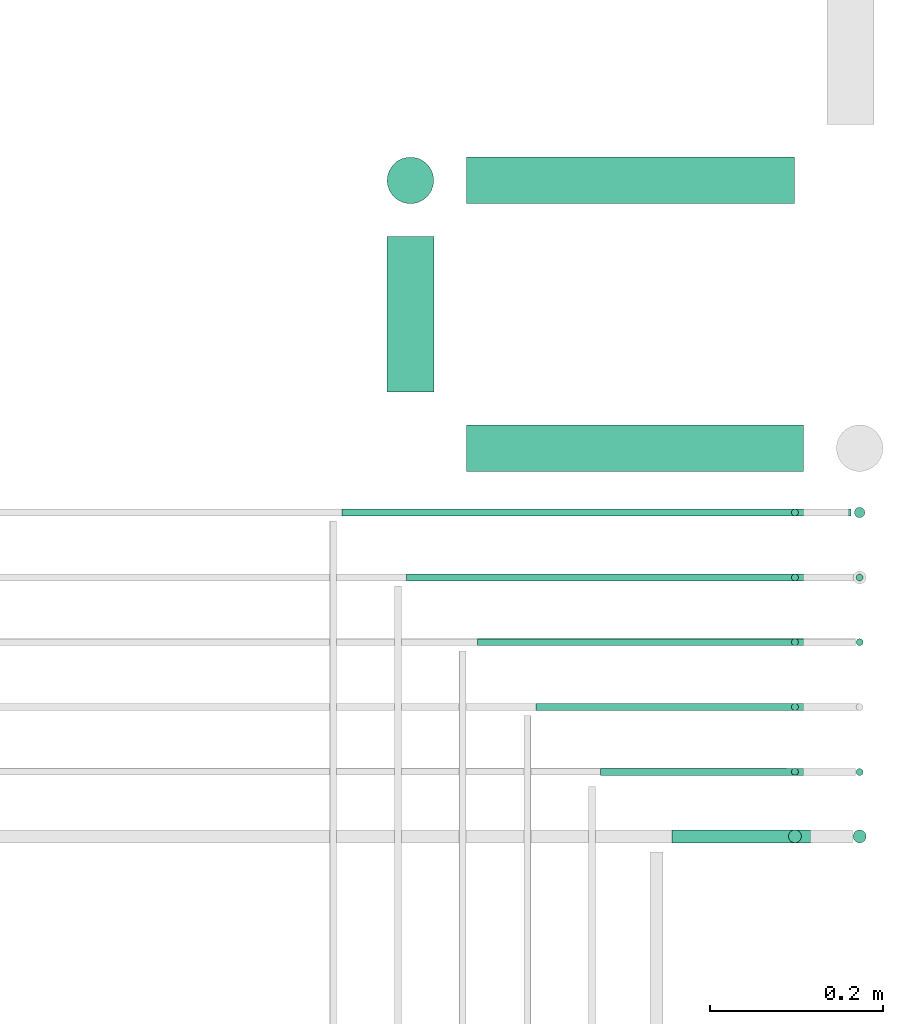
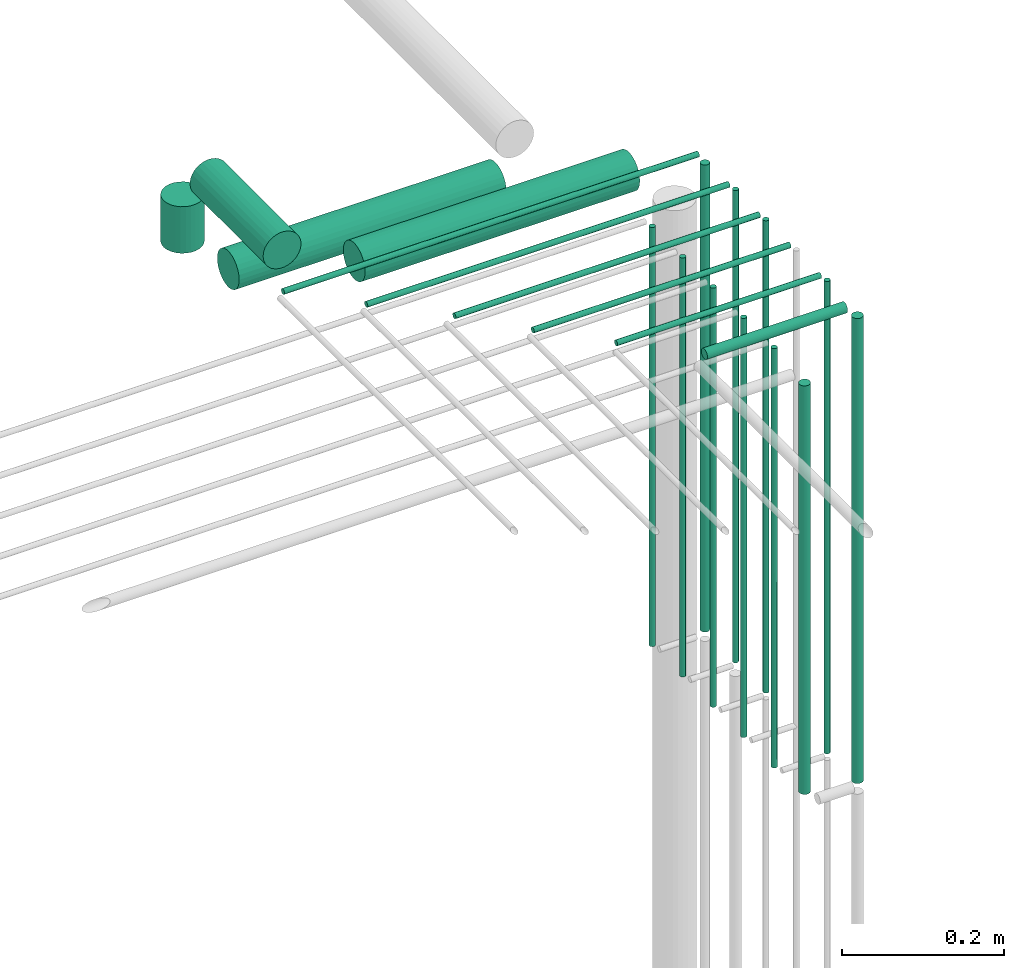
# One storey, part 60 of 89: 21 flow segments.
"""IFC2X3 building model written with IfcOpenShell, lengths in millimetres."""

import ifcopenshell
import ifcopenshell.guid

model = None  # the IFC model being written
_history = None  # IfcOwnerHistory: only IFC2X3 demands one
_inside = {}  # id of a spatial element -> (the spatial element, [elements in it])
_under = {}  # id of a project, library or spatial element -> (it, [spatial elements below it])
_declared = {}  # id of a project -> (the project, [libraries it declares])
_typed = {}  # id of a type object -> (the type object, [elements of that type])
_made_of = {}  # id of a material, layer set ... -> (it, [elements and type objects made of it])


def new_model(schema):
    """Start an empty IFC model of exactly this schema.

    Asked for "IFC4X3", IfcOpenShell would pick the latest addendum, in which some entities
    have other attributes; the version numbers below select the first issue.
    IFC2X3 requires an IfcOwnerHistory on every rooted entity: one is made here for all.
    """
    global model, _history
    if schema == "IFC4X3":
        model = ifcopenshell.file(schema_version=(4, 3, 0, 0))
    else:
        model = ifcopenshell.file(schema=schema)
    _inside.clear()
    _under.clear()
    _declared.clear()
    _typed.clear()
    _made_of.clear()
    _history = None
    if model.schema == "IFC2X3":
        org = make("IfcOrganization", Name="unknown")
        user = make(
            "IfcPersonAndOrganization",
            ThePerson=make("IfcPerson", FamilyName="unknown"),
            TheOrganization=org,
        )
        app = make(
            "IfcApplication",
            ApplicationDeveloper=org,
            Version="unknown",
            ApplicationFullName="unknown",
            ApplicationIdentifier="unknown",
        )
        _history = make(
            "IfcOwnerHistory",
            OwningUser=user,
            OwningApplication=app,
            ChangeAction="ADDED",
            CreationDate=0,
        )
    return model


def make(cls, **values):
    """One entity of the class cls with the attributes given. An attribute that is None is left unset."""
    return model.create_entity(
        cls, **{name: value for name, value in values.items() if value is not None}
    )


def entity(cls, *values):
    """Any entity or typed value of the class cls, its attributes in the order of the schema. None: left unset."""
    e = model.create_entity(cls)
    for i, value in enumerate(values):
        if value is not None:
            e[i] = value
    return e


def rooted(cls, **values):
    """An entity with a GlobalId (a new one), such as an element, a storey or a relation."""
    return make(cls, GlobalId=ifcopenshell.guid.new(), OwnerHistory=_history, **values)


def si_unit(unit_type, name, prefix=None):
    """IfcSIUnit, for example si_unit("LENGTHUNIT", "METRE", prefix="MILLI")."""
    return make("IfcSIUnit", UnitType=unit_type, Prefix=prefix, Name=name)


def converted_unit(unit_type, name, factor, base, dimensions=None, offset=None):
    """IfcConversionBasedUnit, such as the inch: factor (a typed value) times the base unit."""
    return make(
        "IfcConversionBasedUnit"
        if offset is None
        else "IfcConversionBasedUnitWithOffset",
        ConversionOffset=offset,
        Dimensions=None
        if dimensions is None
        else entity("IfcDimensionalExponents", *dimensions),
        UnitType=unit_type,
        Name=name,
        ConversionFactor=make(
            "IfcMeasureWithUnit", ValueComponent=factor, UnitComponent=base
        ),
    )


def derived_unit(unit_type, elements):
    """IfcDerivedUnit: a product of units, each with its exponent."""
    return make(
        "IfcDerivedUnit",
        Elements=[
            make("IfcDerivedUnitElement", Unit=unit, Exponent=power)
            for unit, power in elements
        ],
        UnitType=unit_type,
    )


def assignment(units):
    """IfcUnitAssignment: the units of a project."""
    return None if units is None else make("IfcUnitAssignment", Units=units)


def point(xyz):
    """IfcCartesianPoint."""
    return None if xyz is None else make("IfcCartesianPoint", Coordinates=xyz)


def direction(xyz):
    """IfcDirection."""
    return None if xyz is None else make("IfcDirection", DirectionRatios=xyz)


def frame(location, z_axis=None, x_axis=None):
    """IfcAxis2Placement3D, a coordinate frame: its origin and axes. An axis left out is left unset."""
    return make(
        "IfcAxis2Placement3D",
        Location=point(location),
        Axis=direction(z_axis),
        RefDirection=direction(x_axis),
    )


def frame_2d(location, x_axis=None):
    """IfcAxis2Placement2D, a coordinate frame in the plane: its origin and x axis."""
    return make(
        "IfcAxis2Placement2D", Location=point(location), RefDirection=direction(x_axis)
    )


def origin():
    """The frame at (0, 0, 0) with its axes left unset."""
    return frame((0.0, 0.0, 0.0))


def origin_2d_with_axis():
    """The frame at (0, 0) in the plane with the x axis (1, 0) written out."""
    return frame_2d((0.0, 0.0), x_axis=(1.0, 0.0))


def place(relative_to, where):
    """IfcLocalPlacement: puts the frame where relative to a parent placement (None: the world)."""
    return make(
        "IfcLocalPlacement", PlacementRelTo=relative_to, RelativePlacement=where
    )


def context(
    kind, dimensions, precision=None, world=None, true_north=None, identifier=None
):
    """IfcGeometricRepresentationContext, for example the 3D "Model" context."""
    return make(
        "IfcGeometricRepresentationContext",
        ContextIdentifier=identifier,
        ContextType=kind,
        CoordinateSpaceDimension=dimensions,
        Precision=precision,
        WorldCoordinateSystem=world,
        TrueNorth=true_north,
    )


def subcontext(parent, identifier, kind, view, scale=None):
    """IfcGeometricRepresentationSubContext, for example "Body" below "Model"."""
    return make(
        "IfcGeometricRepresentationSubContext",
        ContextIdentifier=identifier,
        ContextType=kind,
        ParentContext=parent,
        TargetScale=scale,
        TargetView=view,
    )


def project(units=None, contexts=None):
    """IfcProject with its units and contexts."""
    return rooted(
        "IfcProject",
        Name="project",
        RepresentationContexts=contexts,
        UnitsInContext=assignment(units),
    )


def spatial(cls, under=None, at=None, **own):
    """A site, building, storey or space (cls), placed at a placement, below another one or the project."""
    s = rooted(cls, ObjectPlacement=at, **own)
    if under is not None:
        _under.setdefault(under.id(), (under, []))[1].append(s)
    return s


def polyline(points):
    """IfcPolyline through the points."""
    return make("IfcPolyline", Points=[point(p) for p in points])


def profile(cls, at=None, kind="AREA", **sizes):
    """A parametric profile (cls). Its sizes go by their IFC names, for example OverallWidth=200.0."""
    return make(cls, ProfileType=kind, Position=at, **sizes)


def circle(**sizes):
    """IfcCircleProfileDef."""
    return profile("IfcCircleProfileDef", **sizes)


def outline(outer, holes=None, kind="AREA"):
    """IfcArbitraryClosedProfileDef: a profile drawn as a closed curve; with holes, ...WithVoids."""
    if holes is None:
        return make("IfcArbitraryClosedProfileDef", ProfileType=kind, OuterCurve=outer)
    return make(
        "IfcArbitraryProfileDefWithVoids",
        ProfileType=kind,
        OuterCurve=outer,
        InnerCurves=holes,
    )


def extrude(swept, where, along, depth):
    """IfcExtrudedAreaSolid: the profile swept, set in the frame where, extruded along a direction by depth."""
    return make(
        "IfcExtrudedAreaSolid",
        SweptArea=swept,
        Position=where,
        ExtrudedDirection=direction(along),
        Depth=depth,
    )


def shape(context_of_items, identifier, shape_type, items):
    """IfcShapeRepresentation: the items that make up one representation, for example the "Body"."""
    return make(
        "IfcShapeRepresentation",
        ContextOfItems=context_of_items,
        RepresentationIdentifier=identifier,
        RepresentationType=shape_type,
        Items=items,
    )


def made_of(thing, what):
    """Note that an element or type object is made of a material, layer set ...; save() writes the relation."""
    if what is not None:
        _made_of.setdefault(what.id(), (what, []))[1].append(thing)
    return thing


def type_object(cls, material=None, **own):
    """A type object (cls), such as IfcWallType, which elements share."""
    return made_of(rooted(cls, **own), material)


def element(
    cls,
    number,
    at=None,
    inside=None,
    cuts=None,
    type_object=None,
    material=None,
    context=None,
    identifier="Body",
    shape_type=None,
    held_by="IfcProductDefinitionShape",
    body=None,
    shapes=None,
    **own,
):
    """One element of the class cls, such as IfcWall. Its Tag is "e" and its number.

    at: its placement. inside: the storey or other place that contains it. cuts: it is an
    opening in that element (IfcRelVoidsElement). A single representation is given by context,
    identifier, shape_type and body (its items); several are given by shapes. held_by: the class
    of the entity that holds the representations. save() writes the other relations.
    """
    e = rooted(cls, Tag="e%d" % number, ObjectPlacement=at, **own)
    if body is not None:
        shapes = [shape(context, identifier, shape_type, body)]
    if shapes is not None:
        e.Representation = make(held_by, Representations=shapes)
    if inside is not None:
        _inside.setdefault(inside.id(), (inside, []))[1].append(e)
    if cuts is not None:
        rooted(
            "IfcRelVoidsElement", RelatingBuildingElement=cuts, RelatedOpeningElement=e
        )
    if type_object is not None:
        _typed.setdefault(type_object.id(), (type_object, []))[1].append(e)
    return made_of(e, material)


def aggregate(whole, parts):
    """IfcRelAggregates: a whole, such as a stair, and the parts it consists of."""
    return rooted("IfcRelAggregates", RelatingObject=whole, RelatedObjects=parts)


def save(model, path):
    """Write the relations noted so far, then the file.

    IfcRelAggregates (storeys below a building ...), IfcRelContainedInSpatialStructure (elements
    in a storey), IfcRelDefinesByType, IfcRelAssociatesMaterial and IfcRelDeclares: one each for
    every whole, place, type object, material and project.
    """
    for whole, parts in _under.values():
        aggregate(whole, parts)
    for where, things in _inside.values():
        rooted(
            "IfcRelContainedInSpatialStructure",
            RelatedElements=things,
            RelatingStructure=where,
        )
    for kind, things in _typed.values():
        rooted("IfcRelDefinesByType", RelatedObjects=things, RelatingType=kind)
    for what, things in _made_of.values():
        rooted("IfcRelAssociatesMaterial", RelatedObjects=things, RelatingMaterial=what)
    for by, libraries in _declared.values():
        rooted("IfcRelDeclares", RelatingContext=by, RelatedDefinitions=libraries)
    model.write(path)


model = new_model("IFC2X3")

# Units and contexts
model_context = context("Model", 3, precision=0.01, world=origin(), true_north=direction((6.12303176911189e-17, 1.0)))
body_context = subcontext(model_context, "Body", "Model", "MODEL_VIEW")
ifc_project = project(units=[si_unit("LENGTHUNIT", "METRE", prefix="MILLI"), si_unit("AREAUNIT", "SQUARE_METRE"), si_unit("VOLUMEUNIT", "CUBIC_METRE"), converted_unit("PLANEANGLEUNIT", "DEGREE", entity("IfcRatioMeasure", 0.0174532925199433), si_unit("PLANEANGLEUNIT", "RADIAN"), dimensions=[0, 0, 0, 0, 0, 0, 0]), si_unit("MASSUNIT", "GRAM", prefix="KILO"), derived_unit("MASSDENSITYUNIT", [(si_unit("MASSUNIT", "GRAM", prefix="KILO"), 1), (si_unit("LENGTHUNIT", "METRE"), -3)]), derived_unit("MOMENTOFINERTIAUNIT", [(si_unit("LENGTHUNIT", "METRE"), 4)]), si_unit("TIMEUNIT", "SECOND"), si_unit("FREQUENCYUNIT", "HERTZ"), si_unit("THERMODYNAMICTEMPERATUREUNIT", "DEGREE_CELSIUS"), derived_unit("THERMALTRANSMITTANCEUNIT", [(si_unit("MASSUNIT", "GRAM", prefix="KILO"), 1), (si_unit("THERMODYNAMICTEMPERATUREUNIT", "KELVIN"), -1), (si_unit("TIMEUNIT", "SECOND"), -3)]), derived_unit("VOLUMETRICFLOWRATEUNIT", [(si_unit("LENGTHUNIT", "METRE"), 3), (si_unit("TIMEUNIT", "SECOND"), -1)]), derived_unit("MASSFLOWRATEUNIT", [(si_unit("MASSUNIT", "GRAM", prefix="KILO"), 1), (si_unit("TIMEUNIT", "SECOND"), -1)]), derived_unit("ROTATIONALFREQUENCYUNIT", [(si_unit("TIMEUNIT", "SECOND"), -1)]), si_unit("ELECTRICCURRENTUNIT", "AMPERE"), si_unit("ELECTRICVOLTAGEUNIT", "VOLT"), si_unit("POWERUNIT", "WATT"), si_unit("FORCEUNIT", "NEWTON", prefix="KILO"), si_unit("ILLUMINANCEUNIT", "LUX"), si_unit("LUMINOUSFLUXUNIT", "LUMEN"), si_unit("LUMINOUSINTENSITYUNIT", "CANDELA"), derived_unit("USERDEFINED", [(si_unit("MASSUNIT", "GRAM", prefix="KILO"), -1), (si_unit("LENGTHUNIT", "METRE"), -2), (si_unit("TIMEUNIT", "SECOND"), 3), (si_unit("LUMINOUSFLUXUNIT", "LUMEN"), 1)]), derived_unit("LINEARVELOCITYUNIT", [(si_unit("LENGTHUNIT", "METRE"), 1), (si_unit("TIMEUNIT", "SECOND"), -1)]), si_unit("PRESSUREUNIT", "PASCAL"), derived_unit("USERDEFINED", [(si_unit("LENGTHUNIT", "METRE"), -2), (si_unit("MASSUNIT", "GRAM", prefix="KILO"), 1), (si_unit("TIMEUNIT", "SECOND"), -2)]), derived_unit("LINEARFORCEUNIT", [(si_unit("MASSUNIT", "GRAM", prefix="KILO"), 1), (si_unit("LENGTHUNIT", "METRE"), 1), (si_unit("TIMEUNIT", "SECOND"), -2), (si_unit("LENGTHUNIT", "METRE"), -1)]), derived_unit("PLANARFORCEUNIT", [(si_unit("MASSUNIT", "GRAM", prefix="KILO"), 1), (si_unit("LENGTHUNIT", "METRE"), 1), (si_unit("TIMEUNIT", "SECOND"), -2), (si_unit("LENGTHUNIT", "METRE"), -2)])], contexts=[model_context])

# Site, building, storey
site_placement = place(None, frame((0.0, -0.00077364408347762, 0.0)))
site = spatial("IfcSite", under=ifc_project, at=site_placement, CompositionType="ELEMENT")
building_placement = place(site_placement, origin())
building = spatial("IfcBuilding", under=site, at=building_placement, CompositionType="ELEMENT")
storey_placement = place(building_placement, frame((0.0, 0.0, 24000.0)))
storey = spatial("IfcBuildingStorey", under=building, at=storey_placement, CompositionType="ELEMENT", Elevation=24000.0)

# Flow segments
pipe_segment_type = type_object("IfcPipeSegmentType", PredefinedType="NOTDEFINED")
flow_segment_1_placement = place(storey_placement, frame((72851.165211982, 10781.1546458955, 2621.36943576658)))
element("IfcFlowSegment", 1, at=flow_segment_1_placement, inside=storey, type_object=pipe_segment_type, context=body_context, shape_type="SweptSolid", body=[
    extrude(circle(Radius=27.0, at=frame_2d((4.33146851719357e-12, 4.33146851719357e-12), x_axis=(1.0, 0.0))), frame((0.0, 28.5952722359206, 28.5952722359184), z_axis=(1.0, 0.0, 0.0), x_axis=(0.0, 1.0, 0.0)), (0.0, 0.0, 1.0), 390.53232096268),
])
flow_segment_2_placement = place(storey_placement, frame((72863.6417507811, 10579.3450681644, 2693.96296031508)))
element("IfcFlowSegment", 2, at=flow_segment_2_placement, inside=storey, type_object=pipe_segment_type, context=body_context, shape_type="SweptSolid", body=[
    extrude(circle(Radius=4.0, at=origin_2d_with_axis()), frame((0.00408052248035347, 5.59527223591499, 5.59527015458806), z_axis=(0.999999479666625, 0.0, 0.00102013061902209), x_axis=(0.0, 1.0, 0.0)), (0.0, 0.0, 1.0), 433.051926979623),
])
flow_segment_3_placement = place(storey_placement, frame((72706.6456458203, 10729.5815756276, 2694.37722044686)))
element("IfcFlowSegment", 3, at=flow_segment_3_placement, inside=storey, type_object=pipe_segment_type, context=body_context, shape_type="SweptSolid", body=[
    extrude(circle(Radius=4.0, at=frame_2d((0.0, 4.33146851253723e-12), x_axis=(1.0, 0.0))), frame((590.051885859617, 5.59527223591499, 5.59527223161817), z_axis=(-1.0, 0.0, 4.63681411899272e-05), x_axis=(0.0, 1.0, 0.0)), (0.0, 0.0, 1.0), 590.051704599769),
])
flow_segment_4_placement = place(storey_placement, frame((72781.6458313035, 10654.2801511433, 2694.41360666842)))
element("IfcFlowSegment", 4, at=flow_segment_4_placement, inside=storey, type_object=pipe_segment_type, context=body_context, shape_type="SweptSolid", body=[
    extrude(circle(Radius=4.0, at=origin_2d_with_axis()), frame((0.0, 5.59527223591499, 5.59527223591499), z_axis=(1.0, 0.0, 0.0), x_axis=(0.0, 1.0, 0.0)), (0.0, 0.0, 1.0), 515.051701641109),
])
flow_segment_5_placement = place(storey_placement, frame((72931.6458313169, 10504.1012336051, 2694.40472776408)))
element("IfcFlowSegment", 5, at=flow_segment_5_placement, inside=storey, type_object=pipe_segment_type, context=body_context, shape_type="SweptSolid", body=[
    extrude(circle(Radius=4.0, at=origin_2d_with_axis()), frame((0.0, 5.59527223591499, 5.59527223591499), z_axis=(1.0, 0.0, 0.0), x_axis=(0.0, -1.0, 0.0)), (0.0, 0.0, 1.0), 365.051701627707),
])
flow_segment_6_placement = place(storey_placement, frame((73006.6458313035, 10428.8573992404, 2694.40472776409)))
element("IfcFlowSegment", 6, at=flow_segment_6_placement, inside=storey, type_object=pipe_segment_type, context=body_context, shape_type="SweptSolid", body=[
    extrude(circle(Radius=4.0, at=frame_2d((-2.16573425859679e-12, -4.33146851719357e-12), x_axis=(1.0, 0.0))), frame((0.0, 5.59527223591932, 5.59527223591499), z_axis=(1.0, 0.0, 0.0), x_axis=(0.0, 1.0, 0.0)), (0.0, 0.0, 1.0), 290.051701641134),
])
flow_segment_7_placement = place(storey_placement, frame((72757.5699397461, 10874.7481854814, 2621.37360669459)))
element("IfcFlowSegment", 7, at=flow_segment_7_placement, inside=storey, type_object=pipe_segment_type, context=body_context, shape_type="SweptSolid", body=[
    extrude(circle(Radius=27.0, at=origin_2d_with_axis()), frame((28.5952722359184, 0.00173251623651822, 28.5952721803284), z_axis=(0.0, 0.999999997941281, 6.41672680565904e-05), x_axis=(-1.0, 0.0, 0.0)), (0.0, 0.0, 1.0), 180.256417097924),
])
flow_segment_8_placement = place(storey_placement, frame((73089.2388855317, 10350.7755468329, 2690.69570286323)))
element("IfcFlowSegment", 8, at=flow_segment_8_placement, inside=storey, type_object=pipe_segment_type, context=body_context, shape_type="SweptSolid", body=[
    extrude(circle(Radius=7.5, at=origin_2d_with_axis()), frame((0.00786016846629991, 9.09612715559496, 9.09526811709912), z_axis=(0.999999450815124, -4.28636702919149e-06, 0.00104802246089521), x_axis=(4.28636938316136e-06, 1.0, 0.0)), (0.0, 0.0, 1.0), 199.45089678119),
])
flow_segment_9_placement = place(storey_placement, frame((72851.165211982, 11091.4046458955, 2421.40472776407)))
element("IfcFlowSegment", 9, at=flow_segment_9_placement, inside=storey, type_object=pipe_segment_type, context=body_context, shape_type="SweptSolid", body=[
    extrude(circle(Radius=27.0, at=frame_2d((0.0, 4.33146851719357e-12), x_axis=(1.0, 0.0))), frame((0.0, 28.5952722359163, 28.5952722359098), z_axis=(1.0, 0.0, 0.0), x_axis=(0.0, 1.0, 0.0)), (0.0, 0.0, 1.0), 379.916938601133),
])
flow_segment_10_placement = place(storey_placement, frame((72757.569939746, 11091.404646009, 2514.99752453601)))
element("IfcFlowSegment", 10, at=flow_segment_10_placement, inside=storey, type_object=pipe_segment_type, context=body_context, shape_type="SweptSolid", body=[
    extrude(circle(Radius=27.0, at=origin_2d_with_axis()), frame((28.5952722359184, 28.5952721224361, 0.00247546398011309), z_axis=(0.0, 9.16838511216236e-05, 0.999999995797036), x_axis=(-1.0, 0.0, 0.0)), (0.0, 0.0, 1.0), 69.9846166033282),
])
flow_segment_11_placement = place(storey_placement, frame((73299.1022594333, 10727.5815154137, 1982.0)))
element("IfcFlowSegment", 11, at=flow_segment_11_placement, inside=storey, type_object=pipe_segment_type, context=body_context, shape_type="SweptSolid", body=[
    extrude(outline(polyline([(-0.783157153311982, -5.94866916824258), (0.783157153327423, -5.94866916824258), (2.29610059419737, -5.54327719506744), (3.65256857405888, -4.76012004174096), (4.76012004175305, -3.65256857404709), (5.54327719507213, -2.29610059418857), (5.94866916824662, -0.783157153314692), (5.94866916824503, 0.783157153329285), (5.54327719506718, 2.29610059419522), (4.76012004174471, 3.65256857405401), (3.65256857404925, 4.76012004175275), (2.29610059418615, 5.54327719507025), (0.783157153316277, 5.94866916824202), (-0.783157153323128, 5.94866916824202), (-2.29610059419308, 5.54327719506688), (-3.65256857405459, 4.7601200417404), (-4.76012004174876, 3.65256857404652), (-5.54327719506784, 2.29610059418801), (-5.94866916824232, 0.783157153314126), (-5.94866916824074, -0.78315715332985), (-5.54327719506289, -2.29610059419578), (-4.76012004174041, -3.65256857405458), (-3.65256857404495, -4.76012004175332), (-2.29610059418186, -5.54327719507081), (-0.783157153311982, -5.94866916824258)])), frame((7.59527351137608, 7.59527223591454, 5.1466508921294e-07), z_axis=(-1.81808383731324e-09, 8.57783728924682e-08, 1.0), x_axis=(-0.130526192219051, 0.991444861373939, -8.52818345816749e-08)), (0.0, 0.0, 1.0), 701.972028997042),
])
flow_segment_12_placement = place(storey_placement, frame((73226.1022607087, 10729.5815154137, 1985.0)))
element("IfcFlowSegment", 12, at=flow_segment_12_placement, inside=storey, type_object=pipe_segment_type, context=body_context, shape_type="SweptSolid", body=[
    extrude(circle(Radius=4.0, at=origin_2d_with_axis()), frame((5.59527223591499, 5.59527223591499, 0.0)), (0.0, 0.0, 1.0), 629.999999978598),
])
flow_segment_13_placement = place(storey_placement, frame((73226.1022607065, 10654.2776321838, 1984.99997611122)))
element("IfcFlowSegment", 13, at=flow_segment_13_placement, inside=storey, type_object=pipe_segment_type, context=body_context, shape_type="SweptSolid", body=[
    extrude(circle(Radius=4.0, at=origin_2d_with_axis()), frame((5.59527223591499, 5.59527223583486, 2.5861106416869e-05), z_axis=(0.0, 6.46527544176093e-06, 1.0), x_axis=(-1.0, 0.0, 0.0)), (0.0, 0.0, 1.0), 629.999998041058),
])
flow_segment_14_placement = place(storey_placement, frame((73301.1022607087, 10654.2784588154, 1979.99999243841)))
element("IfcFlowSegment", 14, at=flow_segment_14_placement, inside=storey, type_object=pipe_segment_type, context=body_context, shape_type="SweptSolid", body=[
    extrude(circle(Radius=4.0, at=origin_2d_with_axis()), frame((5.59527223591499, 5.59527223590416, 9.53412529725028e-06)), (0.0, 0.0, 1.0), 710.00887693381),
])
flow_segment_15_placement = place(storey_placement, frame((73301.1022607087, 10579.3450681644, 1980.0)))
element("IfcFlowSegment", 15, at=flow_segment_15_placement, inside=storey, type_object=pipe_segment_type, context=body_context, shape_type="SweptSolid", body=[
    extrude(circle(Radius=4.0, at=origin_2d_with_axis()), frame((5.59527223591499, 5.59527223591499, 0.0)), (0.0, 0.0, 1.0), 709.999999999995),
])
flow_segment_16_placement = place(storey_placement, frame((73226.1022607087, 10579.3450681644, 1985.0)))
element("IfcFlowSegment", 16, at=flow_segment_16_placement, inside=storey, type_object=pipe_segment_type, context=body_context, shape_type="SweptSolid", body=[
    extrude(circle(Radius=4.0, at=origin_2d_with_axis()), frame((5.59527223591499, 5.59527223591499, 0.0)), (0.0, 0.0, 1.0), 629.999999999146),
])
flow_segment_17_placement = place(storey_placement, frame((73226.1022607087, 10504.2761002887, 1985.0)))
element("IfcFlowSegment", 17, at=flow_segment_17_placement, inside=storey, type_object=pipe_segment_type, context=body_context, shape_type="SweptSolid", body=[
    extrude(circle(Radius=4.0, at=frame_2d((0.0, -6.68293741308075e-19), x_axis=(1.0, 0.0))), frame((5.59527223591499, 5.59527223591499, 6.1714763432974e-07)), (0.0, 0.0, 1.0), 630.000000027018),
])
flow_segment_18_placement = place(storey_placement, frame((73226.1022607087, 10428.8033018928, 1984.99704178061)))
element("IfcFlowSegment", 18, at=flow_segment_18_placement, inside=storey, type_object=pipe_segment_type, context=body_context, shape_type="SweptSolid", body=[
    extrude(circle(Radius=4.0, at=origin_2d_with_axis()), frame((5.59527223591499, 5.59527111110625, 0.00299974680929154), z_axis=(0.0, 0.000749936702109144, 0.999999718797432), x_axis=(1.0, 0.0, 0.0)), (0.0, 0.0, 1.0), 630.000135630234),
])
flow_segment_19_placement = place(storey_placement, frame((73301.1022607087, 10428.8573992404, 1980.0)))
element("IfcFlowSegment", 19, at=flow_segment_19_placement, inside=storey, type_object=pipe_segment_type, context=body_context, shape_type="SweptSolid", body=[
    extrude(circle(Radius=4.0, at=origin_2d_with_axis()), frame((5.59527223591499, 5.59527223591499, 0.0)), (0.0, 0.0, 1.0), 709.999999999995),
])
flow_segment_20_placement = place(storey_placement, frame((73222.6022607087, 10350.7754696782, 1992.99998582238)))
element("IfcFlowSegment", 20, at=flow_segment_20_placement, inside=storey, type_object=pipe_segment_type, context=body_context, shape_type="SweptSolid", body=[
    extrude(circle(Radius=7.5, at=frame_2d((0.0, 2.16573425859292e-12), x_axis=(1.0, 0.0))), frame((9.09527223591419, 9.0952722359012, 1.41776154805484e-05)), (0.0, 0.0, 1.0), 614.000000001139),
])
flow_segment_21_placement = place(storey_placement, frame((73297.6022607087, 10350.7754696782, 1983.0)))
element("IfcFlowSegment", 21, at=flow_segment_21_placement, inside=storey, type_object=pipe_segment_type, context=body_context, shape_type="SweptSolid", body=[
    extrude(circle(Radius=7.5, at=origin_2d_with_axis()), frame((9.09527223591419, 9.09527223591636, 0.0)), (0.0, 0.0, 1.0), 699.000198160112),
])

save(model, "model.ifc")
